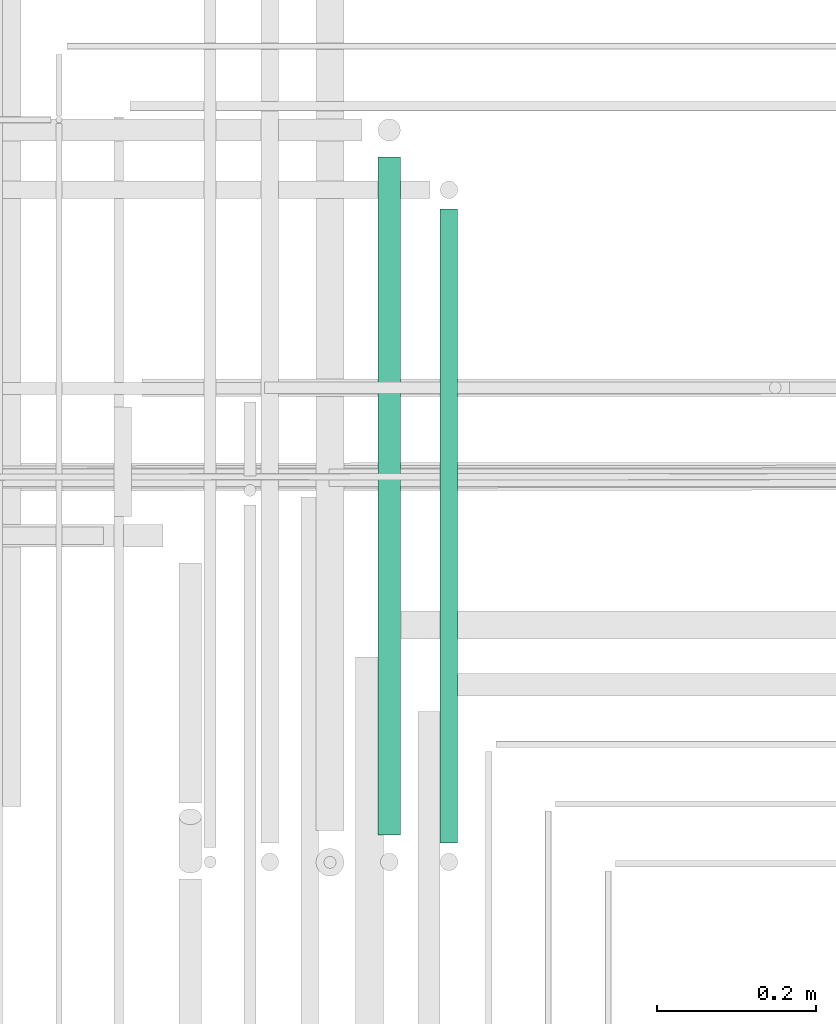
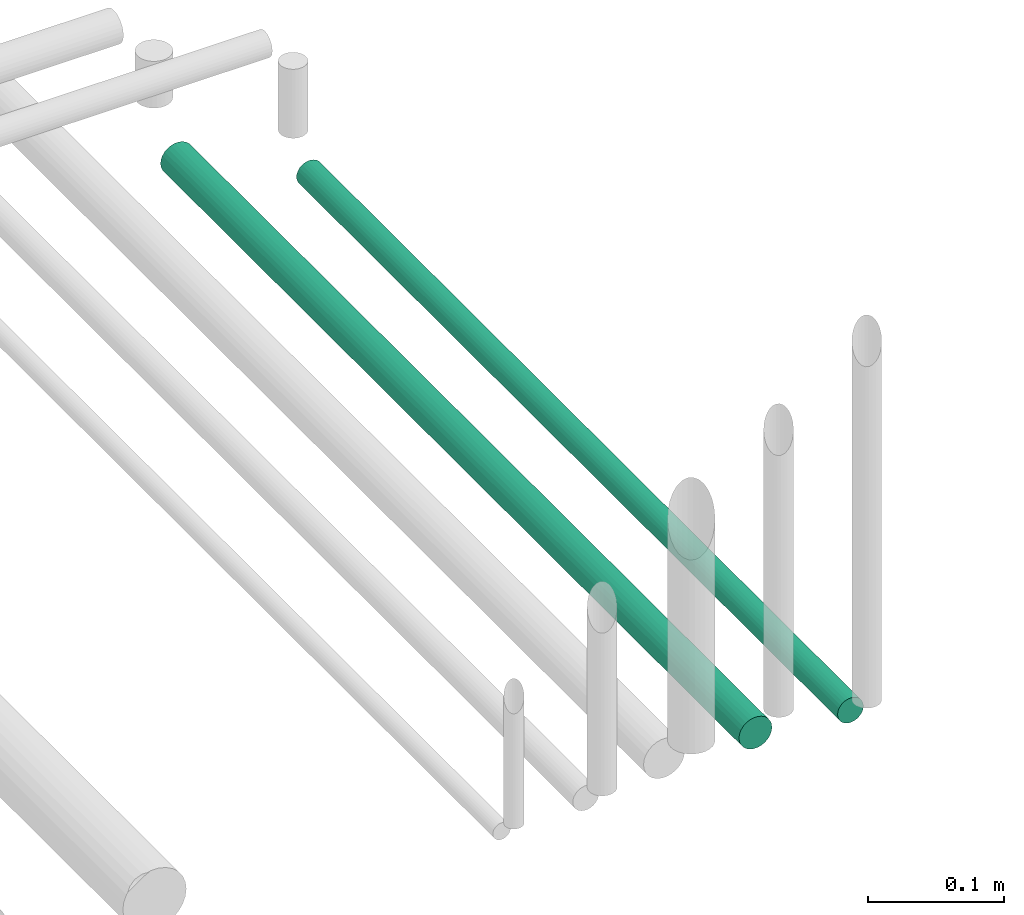
# One storey, part 232 of 331: 2 flow segments.
"""IFC2X3 building model written with IfcOpenShell, lengths in millimetres."""

import ifcopenshell
import ifcopenshell.guid

model = None  # the IFC model being written
_history = None  # IfcOwnerHistory: only IFC2X3 demands one
_inside = {}  # id of a spatial element -> (the spatial element, [elements in it])
_under = {}  # id of a project, library or spatial element -> (it, [spatial elements below it])
_declared = {}  # id of a project -> (the project, [libraries it declares])
_typed = {}  # id of a type object -> (the type object, [elements of that type])
_made_of = {}  # id of a material, layer set ... -> (it, [elements and type objects made of it])


def new_model(schema):
    """Start an empty IFC model of exactly this schema.

    Asked for "IFC4X3", IfcOpenShell would pick the latest addendum, in which some entities
    have other attributes; the version numbers below select the first issue.
    IFC2X3 requires an IfcOwnerHistory on every rooted entity: one is made here for all.
    """
    global model, _history
    if schema == "IFC4X3":
        model = ifcopenshell.file(schema_version=(4, 3, 0, 0))
    else:
        model = ifcopenshell.file(schema=schema)
    _inside.clear()
    _under.clear()
    _declared.clear()
    _typed.clear()
    _made_of.clear()
    _history = None
    if model.schema == "IFC2X3":
        org = make("IfcOrganization", Name="unknown")
        user = make(
            "IfcPersonAndOrganization",
            ThePerson=make("IfcPerson", FamilyName="unknown"),
            TheOrganization=org,
        )
        app = make(
            "IfcApplication",
            ApplicationDeveloper=org,
            Version="unknown",
            ApplicationFullName="unknown",
            ApplicationIdentifier="unknown",
        )
        _history = make(
            "IfcOwnerHistory",
            OwningUser=user,
            OwningApplication=app,
            ChangeAction="ADDED",
            CreationDate=0,
        )
    return model


def make(cls, **values):
    """One entity of the class cls with the attributes given. An attribute that is None is left unset."""
    return model.create_entity(
        cls, **{name: value for name, value in values.items() if value is not None}
    )


def entity(cls, *values):
    """Any entity or typed value of the class cls, its attributes in the order of the schema. None: left unset."""
    e = model.create_entity(cls)
    for i, value in enumerate(values):
        if value is not None:
            e[i] = value
    return e


def rooted(cls, **values):
    """An entity with a GlobalId (a new one), such as an element, a storey or a relation."""
    return make(cls, GlobalId=ifcopenshell.guid.new(), OwnerHistory=_history, **values)


def si_unit(unit_type, name, prefix=None):
    """IfcSIUnit, for example si_unit("LENGTHUNIT", "METRE", prefix="MILLI")."""
    return make("IfcSIUnit", UnitType=unit_type, Prefix=prefix, Name=name)


def converted_unit(unit_type, name, factor, base, dimensions=None, offset=None):
    """IfcConversionBasedUnit, such as the inch: factor (a typed value) times the base unit."""
    return make(
        "IfcConversionBasedUnit"
        if offset is None
        else "IfcConversionBasedUnitWithOffset",
        ConversionOffset=offset,
        Dimensions=None
        if dimensions is None
        else entity("IfcDimensionalExponents", *dimensions),
        UnitType=unit_type,
        Name=name,
        ConversionFactor=make(
            "IfcMeasureWithUnit", ValueComponent=factor, UnitComponent=base
        ),
    )


def derived_unit(unit_type, elements):
    """IfcDerivedUnit: a product of units, each with its exponent."""
    return make(
        "IfcDerivedUnit",
        Elements=[
            make("IfcDerivedUnitElement", Unit=unit, Exponent=power)
            for unit, power in elements
        ],
        UnitType=unit_type,
    )


def assignment(units):
    """IfcUnitAssignment: the units of a project."""
    return None if units is None else make("IfcUnitAssignment", Units=units)


def point(xyz):
    """IfcCartesianPoint."""
    return None if xyz is None else make("IfcCartesianPoint", Coordinates=xyz)


def direction(xyz):
    """IfcDirection."""
    return None if xyz is None else make("IfcDirection", DirectionRatios=xyz)


def frame(location, z_axis=None, x_axis=None):
    """IfcAxis2Placement3D, a coordinate frame: its origin and axes. An axis left out is left unset."""
    return make(
        "IfcAxis2Placement3D",
        Location=point(location),
        Axis=direction(z_axis),
        RefDirection=direction(x_axis),
    )


def frame_2d(location, x_axis=None):
    """IfcAxis2Placement2D, a coordinate frame in the plane: its origin and x axis."""
    return make(
        "IfcAxis2Placement2D", Location=point(location), RefDirection=direction(x_axis)
    )


def origin():
    """The frame at (0, 0, 0) with its axes left unset."""
    return frame((0.0, 0.0, 0.0))


def place(relative_to, where):
    """IfcLocalPlacement: puts the frame where relative to a parent placement (None: the world)."""
    return make(
        "IfcLocalPlacement", PlacementRelTo=relative_to, RelativePlacement=where
    )


def context(
    kind, dimensions, precision=None, world=None, true_north=None, identifier=None
):
    """IfcGeometricRepresentationContext, for example the 3D "Model" context."""
    return make(
        "IfcGeometricRepresentationContext",
        ContextIdentifier=identifier,
        ContextType=kind,
        CoordinateSpaceDimension=dimensions,
        Precision=precision,
        WorldCoordinateSystem=world,
        TrueNorth=true_north,
    )


def subcontext(parent, identifier, kind, view, scale=None):
    """IfcGeometricRepresentationSubContext, for example "Body" below "Model"."""
    return make(
        "IfcGeometricRepresentationSubContext",
        ContextIdentifier=identifier,
        ContextType=kind,
        ParentContext=parent,
        TargetScale=scale,
        TargetView=view,
    )


def project(units=None, contexts=None):
    """IfcProject with its units and contexts."""
    return rooted(
        "IfcProject",
        Name="project",
        RepresentationContexts=contexts,
        UnitsInContext=assignment(units),
    )


def spatial(cls, under=None, at=None, **own):
    """A site, building, storey or space (cls), placed at a placement, below another one or the project."""
    s = rooted(cls, ObjectPlacement=at, **own)
    if under is not None:
        _under.setdefault(under.id(), (under, []))[1].append(s)
    return s


def profile(cls, at=None, kind="AREA", **sizes):
    """A parametric profile (cls). Its sizes go by their IFC names, for example OverallWidth=200.0."""
    return make(cls, ProfileType=kind, Position=at, **sizes)


def circle(**sizes):
    """IfcCircleProfileDef."""
    return profile("IfcCircleProfileDef", **sizes)


def extrude(swept, where, along, depth):
    """IfcExtrudedAreaSolid: the profile swept, set in the frame where, extruded along a direction by depth."""
    return make(
        "IfcExtrudedAreaSolid",
        SweptArea=swept,
        Position=where,
        ExtrudedDirection=direction(along),
        Depth=depth,
    )


def shape(context_of_items, identifier, shape_type, items):
    """IfcShapeRepresentation: the items that make up one representation, for example the "Body"."""
    return make(
        "IfcShapeRepresentation",
        ContextOfItems=context_of_items,
        RepresentationIdentifier=identifier,
        RepresentationType=shape_type,
        Items=items,
    )


def made_of(thing, what):
    """Note that an element or type object is made of a material, layer set ...; save() writes the relation."""
    if what is not None:
        _made_of.setdefault(what.id(), (what, []))[1].append(thing)
    return thing


def type_object(cls, material=None, **own):
    """A type object (cls), such as IfcWallType, which elements share."""
    return made_of(rooted(cls, **own), material)


def element(
    cls,
    number,
    at=None,
    inside=None,
    cuts=None,
    type_object=None,
    material=None,
    context=None,
    identifier="Body",
    shape_type=None,
    held_by="IfcProductDefinitionShape",
    body=None,
    shapes=None,
    **own,
):
    """One element of the class cls, such as IfcWall. Its Tag is "e" and its number.

    at: its placement. inside: the storey or other place that contains it. cuts: it is an
    opening in that element (IfcRelVoidsElement). A single representation is given by context,
    identifier, shape_type and body (its items); several are given by shapes. held_by: the class
    of the entity that holds the representations. save() writes the other relations.
    """
    e = rooted(cls, Tag="e%d" % number, ObjectPlacement=at, **own)
    if body is not None:
        shapes = [shape(context, identifier, shape_type, body)]
    if shapes is not None:
        e.Representation = make(held_by, Representations=shapes)
    if inside is not None:
        _inside.setdefault(inside.id(), (inside, []))[1].append(e)
    if cuts is not None:
        rooted(
            "IfcRelVoidsElement", RelatingBuildingElement=cuts, RelatedOpeningElement=e
        )
    if type_object is not None:
        _typed.setdefault(type_object.id(), (type_object, []))[1].append(e)
    return made_of(e, material)


def aggregate(whole, parts):
    """IfcRelAggregates: a whole, such as a stair, and the parts it consists of."""
    return rooted("IfcRelAggregates", RelatingObject=whole, RelatedObjects=parts)


def save(model, path):
    """Write the relations noted so far, then the file.

    IfcRelAggregates (storeys below a building ...), IfcRelContainedInSpatialStructure (elements
    in a storey), IfcRelDefinesByType, IfcRelAssociatesMaterial and IfcRelDeclares: one each for
    every whole, place, type object, material and project.
    """
    for whole, parts in _under.values():
        aggregate(whole, parts)
    for where, things in _inside.values():
        rooted(
            "IfcRelContainedInSpatialStructure",
            RelatedElements=things,
            RelatingStructure=where,
        )
    for kind, things in _typed.values():
        rooted("IfcRelDefinesByType", RelatedObjects=things, RelatingType=kind)
    for what, things in _made_of.values():
        rooted("IfcRelAssociatesMaterial", RelatedObjects=things, RelatingMaterial=what)
    for by, libraries in _declared.values():
        rooted("IfcRelDeclares", RelatingContext=by, RelatedDefinitions=libraries)
    model.write(path)


model = new_model("IFC2X3")

# Units and contexts
model_context = context("Model", 3, precision=0.01, world=origin(), true_north=direction((6.12303176911189e-17, 1.0)))
body_context = subcontext(model_context, "Body", "Model", "MODEL_VIEW")
ifc_project = project(units=[si_unit("LENGTHUNIT", "METRE", prefix="MILLI"), si_unit("AREAUNIT", "SQUARE_METRE"), si_unit("VOLUMEUNIT", "CUBIC_METRE"), converted_unit("PLANEANGLEUNIT", "DEGREE", entity("IfcRatioMeasure", 0.0174532925199433), si_unit("PLANEANGLEUNIT", "RADIAN"), dimensions=[0, 0, 0, 0, 0, 0, 0]), si_unit("MASSUNIT", "GRAM", prefix="KILO"), derived_unit("MASSDENSITYUNIT", [(si_unit("MASSUNIT", "GRAM", prefix="KILO"), 1), (si_unit("LENGTHUNIT", "METRE"), -3)]), derived_unit("MOMENTOFINERTIAUNIT", [(si_unit("LENGTHUNIT", "METRE"), 4)]), si_unit("TIMEUNIT", "SECOND"), si_unit("FREQUENCYUNIT", "HERTZ"), si_unit("THERMODYNAMICTEMPERATUREUNIT", "DEGREE_CELSIUS"), derived_unit("THERMALTRANSMITTANCEUNIT", [(si_unit("MASSUNIT", "GRAM", prefix="KILO"), 1), (si_unit("THERMODYNAMICTEMPERATUREUNIT", "KELVIN"), -1), (si_unit("TIMEUNIT", "SECOND"), -3)]), derived_unit("VOLUMETRICFLOWRATEUNIT", [(si_unit("LENGTHUNIT", "METRE"), 3), (si_unit("TIMEUNIT", "SECOND"), -1)]), derived_unit("MASSFLOWRATEUNIT", [(si_unit("MASSUNIT", "GRAM", prefix="KILO"), 1), (si_unit("TIMEUNIT", "SECOND"), -1)]), derived_unit("ROTATIONALFREQUENCYUNIT", [(si_unit("TIMEUNIT", "SECOND"), -1)]), si_unit("ELECTRICCURRENTUNIT", "AMPERE"), si_unit("ELECTRICVOLTAGEUNIT", "VOLT"), si_unit("POWERUNIT", "WATT"), si_unit("FORCEUNIT", "NEWTON", prefix="KILO"), si_unit("ILLUMINANCEUNIT", "LUX"), si_unit("LUMINOUSFLUXUNIT", "LUMEN"), si_unit("LUMINOUSINTENSITYUNIT", "CANDELA"), derived_unit("USERDEFINED", [(si_unit("MASSUNIT", "GRAM", prefix="KILO"), -1), (si_unit("LENGTHUNIT", "METRE"), -2), (si_unit("TIMEUNIT", "SECOND"), 3), (si_unit("LUMINOUSFLUXUNIT", "LUMEN"), 1)]), derived_unit("LINEARVELOCITYUNIT", [(si_unit("LENGTHUNIT", "METRE"), 1), (si_unit("TIMEUNIT", "SECOND"), -1)]), si_unit("PRESSUREUNIT", "PASCAL"), derived_unit("USERDEFINED", [(si_unit("LENGTHUNIT", "METRE"), -2), (si_unit("MASSUNIT", "GRAM", prefix="KILO"), 1), (si_unit("TIMEUNIT", "SECOND"), -2)]), derived_unit("LINEARFORCEUNIT", [(si_unit("MASSUNIT", "GRAM", prefix="KILO"), 1), (si_unit("LENGTHUNIT", "METRE"), 1), (si_unit("TIMEUNIT", "SECOND"), -2), (si_unit("LENGTHUNIT", "METRE"), -1)]), derived_unit("PLANARFORCEUNIT", [(si_unit("MASSUNIT", "GRAM", prefix="KILO"), 1), (si_unit("LENGTHUNIT", "METRE"), 1), (si_unit("TIMEUNIT", "SECOND"), -2), (si_unit("LENGTHUNIT", "METRE"), -2)])], contexts=[model_context])

# Site, building, storey
site_placement = place(None, frame((0.0, -0.00077364408347762, 0.0)))
site = spatial("IfcSite", under=ifc_project, at=site_placement, CompositionType="ELEMENT")
building_placement = place(site_placement, origin())
building = spatial("IfcBuilding", under=site, at=building_placement, CompositionType="ELEMENT")
storey_placement = place(building_placement, origin())
storey = spatial("IfcBuildingStorey", under=building, at=storey_placement, CompositionType="ELEMENT", Elevation=0.0)

# Flow segments
pipe_segment_type = type_object("IfcPipeSegmentType", PredefinedType="NOTDEFINED")
flow_segment_1_placement = place(storey_placement, frame((65559.5166110417, 7699.14924977606, 18434.4047277641)))
element("IfcFlowSegment", 1, at=flow_segment_1_placement, inside=storey, type_object=pipe_segment_type, context=body_context, shape_type="SweptSolid", body=[
    extrude(circle(Radius=14.0, at=frame_2d((2.29161975559039e-40, 4.33146851719357e-12), x_axis=(1.0, 0.0))), frame((15.5952722359127, 0.0, 15.595272235917), z_axis=(0.0, 1.0, 0.0), x_axis=(-1.0, 0.0, 0.0)), (0.0, 0.0, 1.0), 851.661484706397),
])
flow_segment_2_placement = place(storey_placement, frame((65637.5166110417, 7689.14912686502, 18437.3924031603)))
element("IfcFlowSegment", 2, at=flow_segment_2_placement, inside=storey, type_object=pipe_segment_type, context=body_context, shape_type="SweptSolid", body=[
    extrude(circle(Radius=11.0, at=frame_2d((0.0, 1.21051528776428e-17), x_axis=(1.0, 0.0))), frame((12.5952722359134, 0.000122966776592648, 12.5952722352269), z_axis=(0.0, 1.0, 1.1178797980031e-05), x_axis=(1.0, 0.0, 0.0)), (0.0, 0.0, 1.0), 796.661484736016),
])

save(model, "model.ifc")
